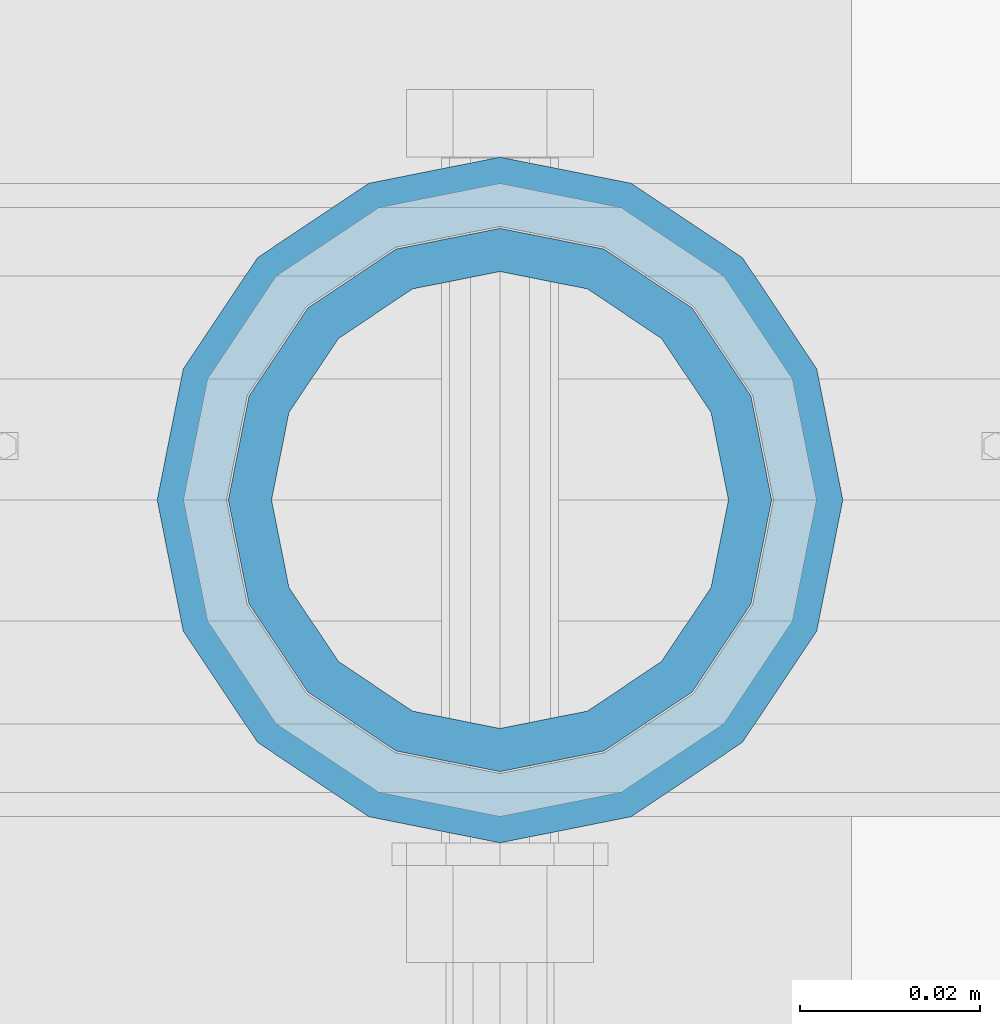
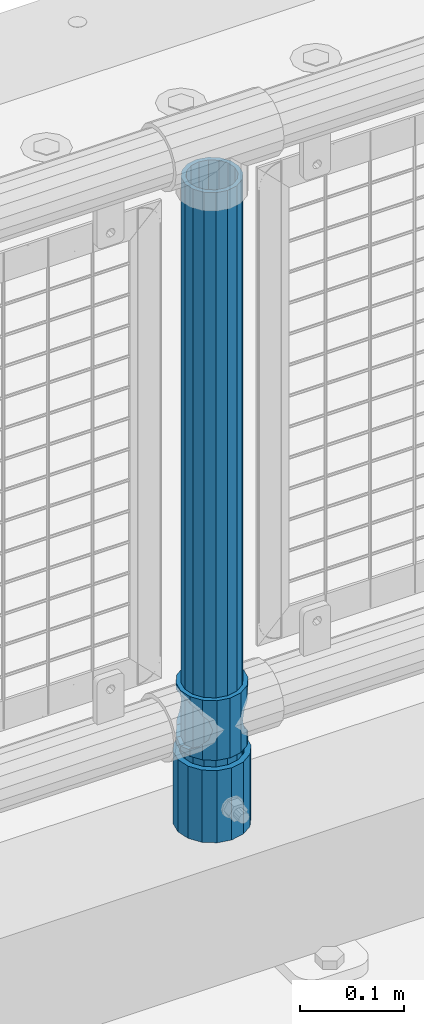
# One storey, part 74 of 208: 3 columns.
"""IFC2X3 building model written with IfcOpenShell, lengths in millimetres."""

import ifcopenshell
import ifcopenshell.guid

model = None  # the IFC model being written
_history = None  # IfcOwnerHistory: only IFC2X3 demands one
_inside = {}  # id of a spatial element -> (the spatial element, [elements in it])
_under = {}  # id of a project, library or spatial element -> (it, [spatial elements below it])
_declared = {}  # id of a project -> (the project, [libraries it declares])
_typed = {}  # id of a type object -> (the type object, [elements of that type])
_made_of = {}  # id of a material, layer set ... -> (it, [elements and type objects made of it])


def new_model(schema):
    """Start an empty IFC model of exactly this schema.

    Asked for "IFC4X3", IfcOpenShell would pick the latest addendum, in which some entities
    have other attributes; the version numbers below select the first issue.
    IFC2X3 requires an IfcOwnerHistory on every rooted entity: one is made here for all.
    """
    global model, _history
    if schema == "IFC4X3":
        model = ifcopenshell.file(schema_version=(4, 3, 0, 0))
    else:
        model = ifcopenshell.file(schema=schema)
    _inside.clear()
    _under.clear()
    _declared.clear()
    _typed.clear()
    _made_of.clear()
    _history = None
    if model.schema == "IFC2X3":
        org = make("IfcOrganization", Name="unknown")
        user = make(
            "IfcPersonAndOrganization",
            ThePerson=make("IfcPerson", FamilyName="unknown"),
            TheOrganization=org,
        )
        app = make(
            "IfcApplication",
            ApplicationDeveloper=org,
            Version="unknown",
            ApplicationFullName="unknown",
            ApplicationIdentifier="unknown",
        )
        _history = make(
            "IfcOwnerHistory",
            OwningUser=user,
            OwningApplication=app,
            ChangeAction="ADDED",
            CreationDate=0,
        )
    return model


def make(cls, **values):
    """One entity of the class cls with the attributes given. An attribute that is None is left unset."""
    return model.create_entity(
        cls, **{name: value for name, value in values.items() if value is not None}
    )


def rooted(cls, **values):
    """An entity with a GlobalId (a new one), such as an element, a storey or a relation."""
    return make(cls, GlobalId=ifcopenshell.guid.new(), OwnerHistory=_history, **values)


def si_unit(unit_type, name, prefix=None):
    """IfcSIUnit, for example si_unit("LENGTHUNIT", "METRE", prefix="MILLI")."""
    return make("IfcSIUnit", UnitType=unit_type, Prefix=prefix, Name=name)


def assignment(units):
    """IfcUnitAssignment: the units of a project."""
    return None if units is None else make("IfcUnitAssignment", Units=units)


def point(xyz):
    """IfcCartesianPoint."""
    return None if xyz is None else make("IfcCartesianPoint", Coordinates=xyz)


def direction(xyz):
    """IfcDirection."""
    return None if xyz is None else make("IfcDirection", DirectionRatios=xyz)


def frame(location, z_axis=None, x_axis=None):
    """IfcAxis2Placement3D, a coordinate frame: its origin and axes. An axis left out is left unset."""
    return make(
        "IfcAxis2Placement3D",
        Location=point(location),
        Axis=direction(z_axis),
        RefDirection=direction(x_axis),
    )


def origin_with_axes():
    """The frame at (0, 0, 0) with the z axis (0, 0, 1) and the x axis (1, 0, 0) written out."""
    return frame((0.0, 0.0, 0.0), z_axis=(0.0, 0.0, 1.0), x_axis=(1.0, 0.0, 0.0))


def place(relative_to, where):
    """IfcLocalPlacement: puts the frame where relative to a parent placement (None: the world)."""
    return make(
        "IfcLocalPlacement", PlacementRelTo=relative_to, RelativePlacement=where
    )


def context(
    kind, dimensions, precision=None, world=None, true_north=None, identifier=None
):
    """IfcGeometricRepresentationContext, for example the 3D "Model" context."""
    return make(
        "IfcGeometricRepresentationContext",
        ContextIdentifier=identifier,
        ContextType=kind,
        CoordinateSpaceDimension=dimensions,
        Precision=precision,
        WorldCoordinateSystem=world,
        TrueNorth=true_north,
    )


def subcontext(parent, identifier, kind, view, scale=None):
    """IfcGeometricRepresentationSubContext, for example "Body" below "Model"."""
    return make(
        "IfcGeometricRepresentationSubContext",
        ContextIdentifier=identifier,
        ContextType=kind,
        ParentContext=parent,
        TargetScale=scale,
        TargetView=view,
    )


def project(units=None, contexts=None):
    """IfcProject with its units and contexts."""
    return rooted(
        "IfcProject",
        Name="project",
        RepresentationContexts=contexts,
        UnitsInContext=assignment(units),
    )


def spatial(cls, under=None, at=None, **own):
    """A site, building, storey or space (cls), placed at a placement, below another one or the project."""
    s = rooted(cls, ObjectPlacement=at, **own)
    if under is not None:
        _under.setdefault(under.id(), (under, []))[1].append(s)
    return s


def faces_of(points, faces, orient=None, outer=None):
    """IfcFace entities. A face is a list of loops; a loop is a list of indices into points, from 0.

    orient and outer hold one flag for each loop. By default every Orientation is true, the
    first loop of a face is its IfcFaceOuterBound and the others are IfcFaceBound.
    """
    made = []
    for i, loops in enumerate(faces):
        bounds = []
        for j, loop in enumerate(loops):
            is_outer = j == 0 if outer is None else outer[i][j]
            bounds.append(
                make(
                    "IfcFaceOuterBound" if is_outer else "IfcFaceBound",
                    Bound=make("IfcPolyLoop", Polygon=[points[k] for k in loop]),
                    Orientation=True if orient is None else orient[i][j],
                )
            )
        made.append(make("IfcFace", Bounds=bounds))
    return made


def faceted_brep(points, faces, orient=None, outer=None, voids=None):
    """IfcFacetedBrep: a solid bounded by flat faces; with voids (closed shells), ...WithVoids."""
    shared = [point(p) for p in points]
    hull = make("IfcClosedShell", CfsFaces=faces_of(shared, faces, orient, outer))
    if voids is None:
        return make("IfcFacetedBrep", Outer=hull)
    return make(
        "IfcFacetedBrepWithVoids",
        Outer=hull,
        Voids=[
            make(cls, CfsFaces=faces_of(shared, fs, o, b)) for cls, fs, o, b in voids
        ],
    )


def shape(context_of_items, identifier, shape_type, items):
    """IfcShapeRepresentation: the items that make up one representation, for example the "Body"."""
    return make(
        "IfcShapeRepresentation",
        ContextOfItems=context_of_items,
        RepresentationIdentifier=identifier,
        RepresentationType=shape_type,
        Items=items,
    )


def material(Name=None, Category=None):
    """IfcMaterial."""
    return make("IfcMaterial", Name=Name, Category=Category)


def made_of(thing, what):
    """Note that an element or type object is made of a material, layer set ...; save() writes the relation."""
    if what is not None:
        _made_of.setdefault(what.id(), (what, []))[1].append(thing)
    return thing


def type_object(cls, material=None, **own):
    """A type object (cls), such as IfcWallType, which elements share."""
    return made_of(rooted(cls, **own), material)


def element(
    cls,
    number,
    at=None,
    inside=None,
    cuts=None,
    type_object=None,
    material=None,
    context=None,
    identifier="Body",
    shape_type=None,
    held_by="IfcProductDefinitionShape",
    body=None,
    shapes=None,
    **own,
):
    """One element of the class cls, such as IfcWall. Its Tag is "e" and its number.

    at: its placement. inside: the storey or other place that contains it. cuts: it is an
    opening in that element (IfcRelVoidsElement). A single representation is given by context,
    identifier, shape_type and body (its items); several are given by shapes. held_by: the class
    of the entity that holds the representations. save() writes the other relations.
    """
    e = rooted(cls, Tag="e%d" % number, ObjectPlacement=at, **own)
    if body is not None:
        shapes = [shape(context, identifier, shape_type, body)]
    if shapes is not None:
        e.Representation = make(held_by, Representations=shapes)
    if inside is not None:
        _inside.setdefault(inside.id(), (inside, []))[1].append(e)
    if cuts is not None:
        rooted(
            "IfcRelVoidsElement", RelatingBuildingElement=cuts, RelatedOpeningElement=e
        )
    if type_object is not None:
        _typed.setdefault(type_object.id(), (type_object, []))[1].append(e)
    return made_of(e, material)


def aggregate(whole, parts):
    """IfcRelAggregates: a whole, such as a stair, and the parts it consists of."""
    return rooted("IfcRelAggregates", RelatingObject=whole, RelatedObjects=parts)


def save(model, path):
    """Write the relations noted so far, then the file.

    IfcRelAggregates (storeys below a building ...), IfcRelContainedInSpatialStructure (elements
    in a storey), IfcRelDefinesByType, IfcRelAssociatesMaterial and IfcRelDeclares: one each for
    every whole, place, type object, material and project.
    """
    for whole, parts in _under.values():
        aggregate(whole, parts)
    for where, things in _inside.values():
        rooted(
            "IfcRelContainedInSpatialStructure",
            RelatedElements=things,
            RelatingStructure=where,
        )
    for kind, things in _typed.values():
        rooted("IfcRelDefinesByType", RelatedObjects=things, RelatingType=kind)
    for what, things in _made_of.values():
        rooted("IfcRelAssociatesMaterial", RelatedObjects=things, RelatingMaterial=what)
    for by, libraries in _declared.values():
        rooted("IfcRelDeclares", RelatingContext=by, RelatedDefinitions=libraries)
    model.write(path)


model = new_model("IFC2X3")

# Units and contexts
model_context = context("Model", 3, precision=1e-05, world=origin_with_axes())
body_context = subcontext(model_context, "Body", "Model", "MODEL_VIEW")
ifc_project = project(units=[si_unit("LENGTHUNIT", "METRE", prefix="MILLI"), si_unit("AREAUNIT", "SQUARE_METRE"), si_unit("VOLUMEUNIT", "CUBIC_METRE"), si_unit("MASSUNIT", "GRAM", prefix="KILO"), si_unit("TIMEUNIT", "SECOND"), si_unit("PLANEANGLEUNIT", "RADIAN"), si_unit("SOLIDANGLEUNIT", "STERADIAN"), si_unit("THERMODYNAMICTEMPERATUREUNIT", "DEGREE_CELSIUS"), si_unit("LUMINOUSINTENSITYUNIT", "LUMEN")], contexts=[model_context])

# Site, building, storey
site_placement = place(None, origin_with_axes())
site = spatial("IfcSite", under=ifc_project, at=site_placement, CompositionType="ELEMENT")
building_placement = place(site_placement, origin_with_axes())
building = spatial("IfcBuilding", under=site, at=building_placement, Name="Standard", CompositionType="ELEMENT")
storey_placement = place(building_placement, origin_with_axes())
storey = spatial("IfcBuildingStorey", under=building, at=storey_placement, Name="Undefined", CompositionType="ELEMENT", Elevation=0.0)

# Columns
ifc_material_1 = material()
column_type_1 = type_object("IfcColumnType", PredefinedType="NOTDEFINED")
column_1_placement = place(storey_placement, frame((-32229.0, 4664.5, 168.02), z_axis=(0.0, 1.0, 0.0), x_axis=(0.0, 0.0, 1.0)))
element("IfcColumn", 1, at=column_1_placement, inside=storey, type_object=column_type_1, material=ifc_material_1, context=body_context, shape_type="Brep", body=[
    faceted_brep([(0.0, -31.75, 0.0), (0.0, -29.3331751572332, 12.1501989775916), (85.0, -29.3331751572332, 12.1501989775916), (85.0, -31.75, 0.0), (0.0, -22.4506403026717, 22.4506403026726), (85.0, -22.4506403026717, 22.4506403026726), (0.0, -12.1501989775934, 29.3331751572332), (85.0, -12.1501989775934, 29.3331751572332), (0.0, 0.0, 31.75), (85.0, 0.0, 31.75), (0.0, 12.1501989775934, 29.3331751572332), (85.0, 12.1501989775934, 29.3331751572332), (0.0, 22.4506403026717, 22.4506403026726), (85.0, 22.4506403026717, 22.4506403026726), (0.0, 29.3331751572332, 12.1501989775916), (85.0, 29.3331751572332, 12.1501989775916), (0.0, 31.75, 0.0), (85.0, 31.75, 0.0), (0.0, 29.3331751572332, -12.1501989775916), (85.0, 29.3331751572332, -12.1501989775916), (0.0, 22.4506403026717, -22.4506403026726), (85.0, 22.4506403026717, -22.4506403026726), (0.0, 12.1501989775934, -29.3331751572332), (85.0, 12.1501989775934, -29.3331751572332), (0.0, 0.0, -31.75), (85.0, 0.0, -31.75), (0.0, -12.1501989775934, -29.3331751572332), (85.0, -12.1501989775934, -29.3331751572332), (0.0, -22.4506403026717, -22.4506403026726), (85.0, -22.4506403026717, -22.4506403026726), (0.0, -29.3331751572332, -12.1501989775916), (85.0, -29.3331751572332, -12.1501989775916), (0.0, -38.0499999999993, 0.0), (0.0, -35.1536162120537, -14.5611046014919), (85.0, -35.1536162120537, -14.5611046014919), (85.0, -38.0499999999993, 0.0), (0.0, -26.9054130241493, -26.9054130241484), (85.0, -26.9054130241493, -26.9054130241484), (0.0, -14.5611046014928, -35.1536162120547), (85.0, -14.5611046014928, -35.1536162120547), (0.0, 0.0, -38.0500000000002), (85.0, 0.0, -38.0500000000002), (0.0, 14.5611046014928, -35.1536162120547), (85.0, 14.5611046014928, -35.1536162120547), (0.0, 26.9054130241493, -26.9054130241484), (85.0, 26.9054130241493, -26.9054130241484), (0.0, 35.1536162120537, -14.5611046014919), (85.0, 35.1536162120537, -14.5611046014919), (0.0, 38.0499999999993, 0.0), (85.0, 38.0499999999993, 0.0), (0.0, 35.1536162120537, 14.5611046014919), (85.0, 35.1536162120537, 14.5611046014919), (0.0, 26.9054130241493, 26.9054130241484), (85.0, 26.9054130241493, 26.9054130241484), (0.0, 14.5611046014928, 35.1536162120547), (85.0, 14.5611046014928, 35.1536162120547), (0.0, 0.0, 38.0500000000002), (85.0, 0.0, 38.0500000000002), (0.0, -14.5611046014928, 35.1536162120547), (85.0, -14.5611046014928, 35.1536162120547), (0.0, -26.9054130241493, 26.9054130241484), (85.0, -26.9054130241493, 26.9054130241484), (0.0, -35.1536162120537, 14.5611046014919), (85.0, -35.1536162120537, 14.5611046014919)], [[[0, 1, 2, 3]], [[1, 4, 5, 2]], [[4, 6, 7, 5]], [[6, 8, 9, 7]], [[8, 10, 11, 9]], [[10, 12, 13, 11]], [[12, 14, 15, 13]], [[14, 16, 17, 15]], [[16, 18, 19, 17]], [[18, 20, 21, 19]], [[20, 22, 23, 21]], [[22, 24, 25, 23]], [[24, 26, 27, 25]], [[26, 28, 29, 27]], [[28, 30, 31, 29]], [[30, 0, 3, 31]], [[32, 33, 34, 35]], [[33, 36, 37, 34]], [[36, 38, 39, 37]], [[38, 40, 41, 39]], [[40, 42, 43, 41]], [[42, 44, 45, 43]], [[44, 46, 47, 45]], [[46, 48, 49, 47]], [[48, 50, 51, 49]], [[50, 52, 53, 51]], [[52, 54, 55, 53]], [[54, 56, 57, 55]], [[56, 58, 59, 57]], [[58, 60, 61, 59]], [[60, 62, 63, 61]], [[62, 32, 35, 63]], [[37, 39, 41, 43, 45, 47, 49, 51, 53, 55, 57, 59, 61, 63, 35, 34], [5, 7, 9, 11, 13, 15, 17, 19, 21, 23, 25, 27, 29, 31, 3, 2]], [[62, 60, 58, 56, 54, 52, 50, 48, 46, 44, 42, 40, 38, 36, 33, 32], [30, 28, 26, 24, 22, 20, 18, 16, 14, 12, 10, 8, 6, 4, 1, 0]]]),
])
ifc_material_2 = material(Name="Misc_Undefined")
column_type_2 = type_object("IfcColumnType", PredefinedType="NOTDEFINED")
column_2_placement = place(storey_placement, frame((-32229.0, 4664.5, 263.02), z_axis=(-1.0, 0.0, 0.0), x_axis=(0.0, 0.0, 1.0)))
element("IfcColumn", 2, at=column_2_placement, inside=storey, type_object=column_type_2, material=ifc_material_2, context=body_context, shape_type="Brep", body=[
    faceted_brep([(63.1897438117172, 11.6144421722802, -32.8397438117245), (63.1897438117172, 11.6144421722802, -28.0397438117143), (56.6106908090114, 21.4606908090118, -21.4606908090136), (56.6106908090114, 21.4606908090118, -27.1226768591077), (61.962379517676, 13.4513226476329, -32.4743655677739), (46.7644421722801, 28.0397438117179, -11.6144421722784), (46.7644421722801, 28.0397438117179, -20.0882031229921), (51.531042408003, 24.8548033587067, -24.8548033587067), (35.1500000000015, 30.35, 0.0), (35.1499999999996, 30.3500000000004, -16.6306603983685), (23.5355578277192, 28.0397438117179, -11.6144421722784), (23.5355578277192, 28.0397438117179, -20.0882031229921), (18.7689575919962, 24.8548033587067, -24.8548033587067), (13.6893091909879, 21.4606908090118, -21.4606908090136), (13.6893091909879, 21.4606908090118, -27.1226768591077), (8.33762048232325, 13.4513226476329, -32.4743655677739), (7.11025618828211, 11.6144421722802, -28.0397438117143), (7.11025618828211, 11.6144421722802, -32.8397438117245), (4.79999999999961, 0.0, -30.3499999999985), (4.79999999999961, 0.0, -35.1500000000015), (7.11025618828205, -11.6144421722802, -28.0397438117143), (7.11025618828205, -11.6144421722802, -32.8397438117245), (13.6893091909879, -21.4606908090118, -21.4606908090136), (13.6893091909879, -21.4606908090118, -27.1226768591005), (8.33762048232325, -13.4513226476329, -32.4743655677739), (23.5355578277191, -28.0397438117179, -11.6144421722784), (23.5355578277191, -28.0397438117179, -20.0882031229921), (18.7689575919962, -24.8548033587067, -24.8548033587067), (35.1500000000015, -30.35, 0.0), (35.1499999999996, -30.3500000000004, -16.6306603983685), (46.7644421722801, -28.0397438117179, -11.6144421722784), (46.7644421722801, -28.0397438117179, -20.0882031229921), (51.531042408003, -24.8548033587067, -24.8548033587067), (56.6106908090114, -21.4606908090118, -21.4606908090136), (56.6106908090114, -21.4606908090118, -27.1226768591005), (61.962379517675, -13.4513226476329, -32.4743655677739), (63.1897438117172, -11.6144421722802, -28.0397438117143), (63.1897438117172, -11.6144421722802, -32.8397438117245), (65.4999999999997, 0.0, -30.3499999999985), (65.4999999999997, 0.0, -35.1500000000015), (0.0, -28.0397438117179, -11.6144421722784), (0.0, -30.3500000000004, 0.0), (0.0, -21.4606908090118, -21.4606908090136), (0.0, -11.6144421722802, -28.0397438117143), (0.0, 0.0, -30.3499999999985), (0.0, 11.6144421722802, -28.0397438117143), (0.0, 21.4606908090118, -21.4606908090136), (0.0, 28.0397438117179, -11.6144421722784), (0.0, 30.3500000000004, 0.0), (0.0, 28.0397438117179, 11.6144421722784), (23.5355578277192, 28.0397438117179, 11.6144421722784), (0.0, 21.4606908090118, 21.4606908090136), (13.6893091909879, 21.4606908090118, 21.4606908090136), (0.0, 11.6144421722802, 28.0397438117143), (7.11025618828211, 11.6144421722802, 28.0397438117143), (0.0, 0.0, 30.3499999999985), (4.79999999999961, 0.0, 30.3499999999985), (0.0, -11.6144421722802, 28.0397438117143), (7.11025618828205, -11.6144421722802, 28.0397438117143), (0.0, -21.4606908090118, 21.4606908090136), (13.6893091909879, -21.4606908090118, 21.4606908090136), (0.0, -28.0397438117179, 11.6144421722784), (23.5355578277191, -28.0397438117179, 11.6144421722784), (0.0, -32.4743655677721, 13.4513226476338), (0.0, -35.1499999999996, 0.0), (70.2999999999993, -35.1499999999996, 0.0), (70.2999999999993, -32.4743655677721, 13.4513226476338), (0.0, 13.4513226476329, -32.4743655677739), (0.0, 24.8548033587067, -24.8548033587067), (0.0, 0.0, -35.1499999999996), (0.0, -13.4513226476329, -32.4743655677739), (0.0, -24.8548033587067, -24.8548033587067), (0.0, -24.8548033587067, 24.8548033587067), (0.0, -13.4513226476329, 32.4743655677739), (0.0, 0.0, 35.1499999999996), (0.0, 13.4513226476329, 32.4743655677739), (0.0, 24.8548033587067, 24.8548033587067), (0.0, 32.4743655677721, 13.4513226476338), (0.0, 35.1499999999996, 0.0), (0.0, 32.4743655677721, -13.4513226476338), (0.0, -32.4743655677721, -13.4513226476338), (70.2999999999993, 32.4743655677721, 13.4513226476338), (70.2999999999993, 35.1499999999996, 0.0), (70.2999999999993, 32.4743655677721, -13.4513226476338), (70.2999999999993, 24.8548033587067, -24.8548033587067), (70.2999999999993, 13.4513226476329, -32.4743655677739), (70.2999999999993, 0.0, -35.1500000000015), (70.2999999999993, -13.4513226476329, -32.4743655677739), (70.2999999999993, -24.8548033587067, -24.8548033587067), (70.2999999999993, -32.4743655677721, -13.4513226476338), (70.2999999999993, 28.0397438117179, 11.6144421722784), (70.2999999999993, 21.4606908090118, 21.4606908090136), (56.6106908090114, 21.4606908090118, 21.4606908090136), (46.7644421722801, 28.0397438117179, 11.6144421722784), (70.2999999999993, 11.6144421722802, 28.0397438117143), (63.1897438117172, 11.6144421722802, 28.0397438117143), (70.2999999999993, 0.0, 30.3499999999985), (65.4999999999997, 0.0, 30.3499999999985), (70.2999999999993, -11.6144421722802, 28.0397438117143), (63.1897438117172, -11.6144421722802, 28.0397438117143), (70.2999999999993, -21.4606908090118, 21.4606908090136), (56.6106908090114, -21.4606908090118, 21.4606908090136), (70.2999999999993, -28.0397438117179, 11.6144421722784), (46.7644421722801, -28.0397438117179, 11.6144421722784), (70.2999999999993, -11.6144421722802, -28.0397438117143), (70.2999999999993, 0.0, -30.3499999999985), (70.2999999999993, -21.4606908090118, -21.4606908090136), (70.2999999999993, -28.0397438117179, -11.6144421722784), (70.2999999999993, -30.3500000000004, 0.0), (70.2999999999993, 24.8548033587067, 24.8548033587067), (70.2999999999993, 13.4513226476329, 32.4743655677739), (70.2999999999993, 0.0, 35.1500000000015), (70.2999999999993, -13.4513226476329, 32.4743655677739), (70.2999999999993, -24.8548033587067, 24.8548033587067), (70.2999999999993, 30.3500000000004, 0.0), (70.2999999999993, 28.0397438117179, -11.6144421722784), (70.2999999999993, 21.4606908090118, -21.4606908090136), (70.2999999999993, 11.6144421722802, -28.0397438117143), (61.9623795176756, 13.4513226476329, 32.4743655677739), (51.531042408003, 24.8548033587067, 24.8548033587067), (56.6106908090114, 21.4606908090118, 27.1226768591005), (65.4999999999997, 0.0, 35.1500000000015), (63.1897438117172, 11.6144421722802, 32.8397438117172), (63.1897438117172, -11.6144421722802, 32.8397438117245), (61.962379517675, -13.4513226476329, 32.4743655677739), (56.6106908090114, -21.4606908090118, 27.1226768591077), (51.531042408003, -24.8548033587067, 24.8548033587067), (18.7689575919962, -24.8548033587067, 24.8548033587067), (46.7644421722801, -28.0397438117179, 20.0882031229776), (35.1499999999996, -30.3500000000004, 16.6306603983612), (23.5355578277191, -28.0397438117179, 20.0882031229776), (8.3376204823237, -13.4513226476329, 32.4743655677739), (13.6893091909879, -21.4606908090118, 27.1226768591077), (4.79999999999961, 0.0, 35.1500000000015), (7.11025618828205, -11.6144421722802, 32.8397438117245), (7.11025618828211, 11.6144421722802, 32.8397438117172), (8.3376204823237, 13.4513226476329, 32.4743655677739), (13.6893091909879, 21.4606908090118, 27.1226768591005), (18.7689575919962, 24.8548033587067, 24.8548033587067), (23.5355578277192, 28.0397438117179, 20.0882031229921), (35.1499999999996, 30.3500000000004, 16.6306603983685), (46.7644421722801, 28.0397438117179, 20.0882031229921)], [[[0, 1, 2, 3, 4]], [[3, 2, 5, 6, 7]], [[6, 5, 8, 9]], [[9, 8, 10, 11]], [[12, 11, 10, 13, 14]], [[15, 14, 13, 16, 17]], [[17, 16, 18, 19]], [[19, 18, 20, 21]], [[21, 20, 22, 23, 24]], [[23, 22, 25, 26, 27]], [[26, 25, 28, 29]], [[29, 28, 30, 31]], [[32, 31, 30, 33, 34]], [[35, 34, 33, 36, 37]], [[37, 36, 38, 39]], [[39, 38, 1, 0]], [[40, 41, 28, 25]], [[42, 40, 25, 22]], [[43, 42, 22, 20]], [[44, 43, 20, 18]], [[45, 44, 18, 16]], [[46, 45, 16, 13]], [[47, 46, 13, 10]], [[48, 47, 10, 8]], [[49, 48, 8, 50]], [[51, 49, 50, 52]], [[53, 51, 52, 54]], [[55, 53, 54, 56]], [[57, 55, 56, 58]], [[59, 57, 58, 60]], [[61, 59, 60, 62]], [[41, 61, 62, 28]], [[63, 64, 65, 66]], [[67, 68, 12, 14, 15]], [[69, 67, 15, 17, 19]], [[24, 70, 69, 19, 21]], [[27, 71, 70, 24, 23]], [[63, 72, 73, 74, 75, 76, 77, 78, 79, 68, 67, 69, 70, 71, 80, 64], [40, 42, 43, 44, 45, 46, 47, 48, 49, 51, 53, 55, 57, 59, 61, 41]], [[78, 77, 81, 82]], [[79, 78, 82, 83]], [[9, 11, 12, 68, 79, 83, 84, 7, 6]], [[7, 84, 85, 4, 3]], [[4, 85, 86, 39, 0]], [[87, 88, 32, 34, 35]], [[86, 87, 35, 37, 39]], [[88, 89, 80, 71, 27, 26, 29, 31, 32]], [[64, 80, 89, 65]], [[90, 91, 92, 93]], [[91, 94, 95, 92]], [[94, 96, 97, 95]], [[96, 98, 99, 97]], [[98, 100, 101, 99]], [[100, 102, 103, 101]], [[104, 105, 38, 36]], [[106, 104, 36, 33]], [[107, 106, 33, 30]], [[108, 107, 30, 28]], [[102, 108, 28, 103]], [[88, 87, 86, 85, 84, 83, 82, 81, 109, 110, 111, 112, 113, 66, 65, 89], [100, 98, 96, 94, 91, 90, 114, 115, 116, 117, 105, 104, 106, 107, 108, 102]], [[118, 110, 109, 119, 120]], [[121, 111, 110, 118, 122]], [[112, 111, 121, 123, 124]], [[113, 112, 124, 125, 126]], [[127, 72, 63, 66, 113, 126, 128, 129, 130]], [[131, 73, 72, 127, 132]], [[133, 74, 73, 131, 134]], [[75, 74, 133, 135, 136]], [[76, 75, 136, 137, 138]], [[119, 109, 81, 77, 76, 138, 139, 140, 141]], [[92, 120, 119, 141, 93]], [[95, 122, 118, 120, 92]], [[97, 121, 122, 95]], [[99, 123, 121, 97]], [[101, 125, 124, 123, 99]], [[103, 128, 126, 125, 101]], [[28, 129, 128, 103]], [[62, 130, 129, 28]], [[60, 132, 127, 130, 62]], [[58, 134, 131, 132, 60]], [[56, 133, 134, 58]], [[54, 135, 133, 56]], [[52, 137, 136, 135, 54]], [[50, 139, 138, 137, 52]], [[8, 140, 139, 50]], [[93, 141, 140, 8]], [[114, 90, 93, 8]], [[115, 114, 8, 5]], [[116, 115, 5, 2]], [[117, 116, 2, 1]], [[105, 117, 1, 38]]]),
])
column_type_3 = type_object("IfcColumnType", PredefinedType="NOTDEFINED")
column_3_placement = place(storey_placement, frame((-32229.0, 4664.5, 168.02), z_axis=(-1.0, 0.0, 0.0), x_axis=(0.0, 0.0, 1.0)))
element("IfcColumn", 3, at=column_3_placement, inside=storey, type_object=column_type_3, material=ifc_material_1, context=body_context, shape_type="Brep", body=[
    faceted_brep([(0.0, -25.3500000000004, 0.0), (0.0, -23.4203461491616, 9.70102501045403), (760.0, -23.4203461491616, 9.70102501045403), (760.0, -25.3500000000004, 0.0), (0.0, -17.9251569030794, 17.9251569030785), (760.0, -17.9251569030794, 17.9251569030785), (0.0, -9.70102501045494, 23.4203461491597), (760.0, -9.70102501045494, 23.4203461491597), (0.0, 0.0, 25.3499999999985), (760.0, 0.0, 25.3499999999985), (0.0, 9.70102501045494, 23.4203461491597), (760.0, 9.70102501045494, 23.4203461491597), (0.0, 17.9251569030794, 17.9251569030785), (760.0, 17.9251569030794, 17.9251569030785), (0.0, 23.4203461491616, 9.70102501045403), (760.0, 23.4203461491616, 9.70102501045403), (0.0, 25.3500000000004, 0.0), (760.0, 25.3500000000004, 0.0), (0.0, 23.4203461491616, -9.70102501045403), (760.0, 23.4203461491616, -9.70102501045403), (0.0, 17.9251569030794, -17.9251569030785), (760.0, 17.9251569030794, -17.9251569030785), (0.0, 9.70102501045494, -23.4203461491597), (760.0, 9.70102501045494, -23.4203461491597), (0.0, 0.0, -25.3499999999985), (760.0, 0.0, -25.3499999999985), (0.0, -9.70102501045494, -23.4203461491597), (760.0, -9.70102501045494, -23.4203461491597), (0.0, -17.9251569030794, -17.9251569030785), (760.0, -17.9251569030794, -17.9251569030785), (0.0, -23.4203461491616, -9.70102501045403), (760.0, -23.4203461491616, -9.70102501045403), (0.0, -30.1499999999996, 0.0), (0.0, -27.8549679052148, -11.5379054858058), (760.0, -27.8549679052148, -11.5379054858058), (760.0, -30.1499999999996, 0.0), (0.0, -21.3192694527743, -21.3192694527752), (760.0, -21.3192694527743, -21.3192694527752), (0.0, -11.5379054858076, -27.8549679052157), (760.0, -11.5379054858076, -27.8549679052157), (0.0, 0.0, -30.1500000000015), (760.0, 0.0, -30.1500000000015), (0.0, 11.5379054858076, -27.8549679052157), (760.0, 11.5379054858076, -27.8549679052157), (0.0, 21.3192694527743, -21.3192694527752), (760.0, 21.3192694527743, -21.3192694527752), (0.0, 27.8549679052157, -11.5379054858058), (760.0, 27.8549679052157, -11.5379054858058), (0.0, 30.1499999999996, 0.0), (760.0, 30.1499999999996, 0.0), (0.0, 27.8549679052157, 11.5379054858058), (760.0, 27.8549679052157, 11.5379054858058), (0.0, 21.3192694527743, 21.3192694527752), (760.0, 21.3192694527743, 21.3192694527752), (0.0, 11.5379054858076, 27.8549679052157), (760.0, 11.5379054858076, 27.8549679052157), (0.0, 0.0, 30.1500000000015), (760.0, 0.0, 30.1500000000015), (0.0, -11.5379054858076, 27.8549679052157), (760.0, -11.5379054858076, 27.8549679052157), (0.0, -21.3192694527743, 21.3192694527752), (760.0, -21.3192694527743, 21.3192694527752), (0.0, -27.8549679052157, 11.5379054858058), (760.0, -27.8549679052157, 11.5379054858058)], [[[0, 1, 2, 3]], [[1, 4, 5, 2]], [[4, 6, 7, 5]], [[6, 8, 9, 7]], [[8, 10, 11, 9]], [[10, 12, 13, 11]], [[12, 14, 15, 13]], [[14, 16, 17, 15]], [[16, 18, 19, 17]], [[18, 20, 21, 19]], [[20, 22, 23, 21]], [[22, 24, 25, 23]], [[24, 26, 27, 25]], [[26, 28, 29, 27]], [[28, 30, 31, 29]], [[30, 0, 3, 31]], [[32, 33, 34, 35]], [[33, 36, 37, 34]], [[36, 38, 39, 37]], [[38, 40, 41, 39]], [[40, 42, 43, 41]], [[42, 44, 45, 43]], [[44, 46, 47, 45]], [[46, 48, 49, 47]], [[48, 50, 51, 49]], [[50, 52, 53, 51]], [[52, 54, 55, 53]], [[54, 56, 57, 55]], [[56, 58, 59, 57]], [[58, 60, 61, 59]], [[60, 62, 63, 61]], [[62, 32, 35, 63]], [[37, 39, 41, 43, 45, 47, 49, 51, 53, 55, 57, 59, 61, 63, 35, 34], [5, 7, 9, 11, 13, 15, 17, 19, 21, 23, 25, 27, 29, 31, 3, 2]], [[62, 60, 58, 56, 54, 52, 50, 48, 46, 44, 42, 40, 38, 36, 33, 32], [30, 28, 26, 24, 22, 20, 18, 16, 14, 12, 10, 8, 6, 4, 1, 0]]]),
])

save(model, "model.ifc")
